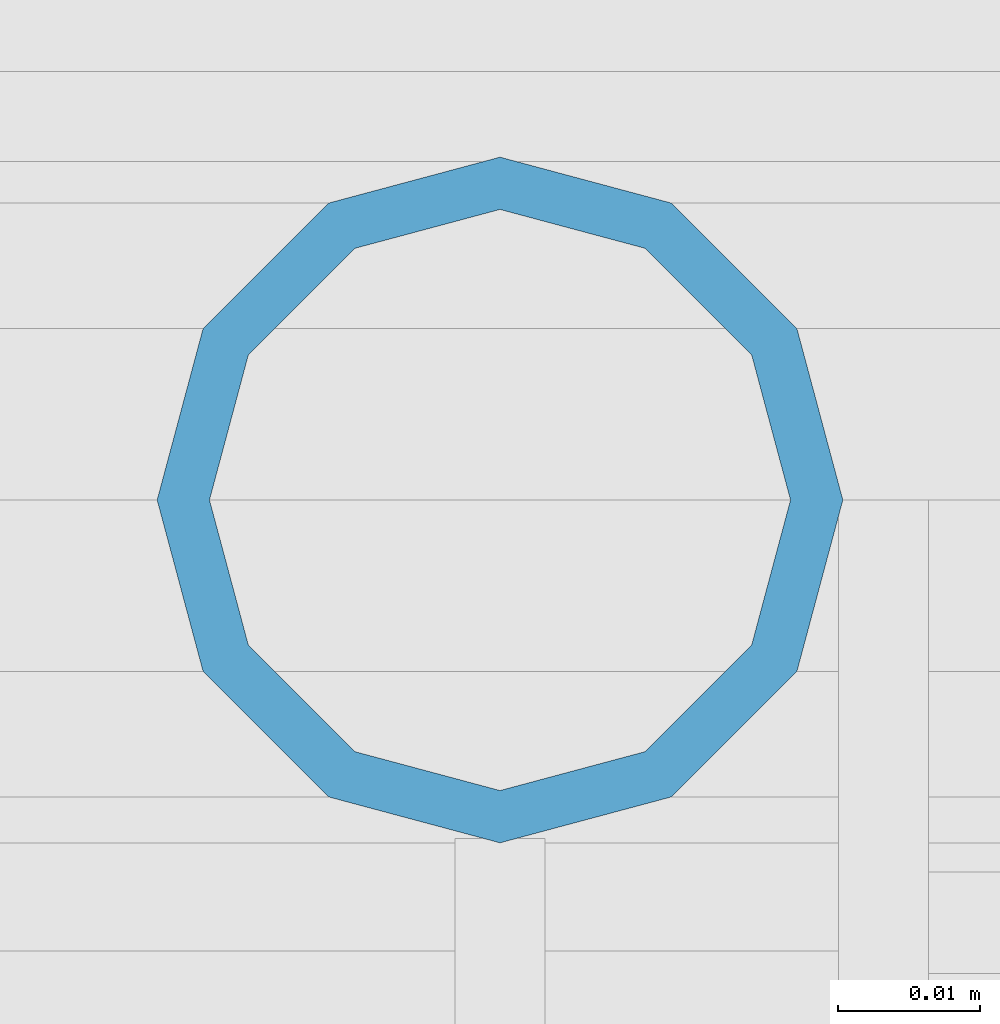
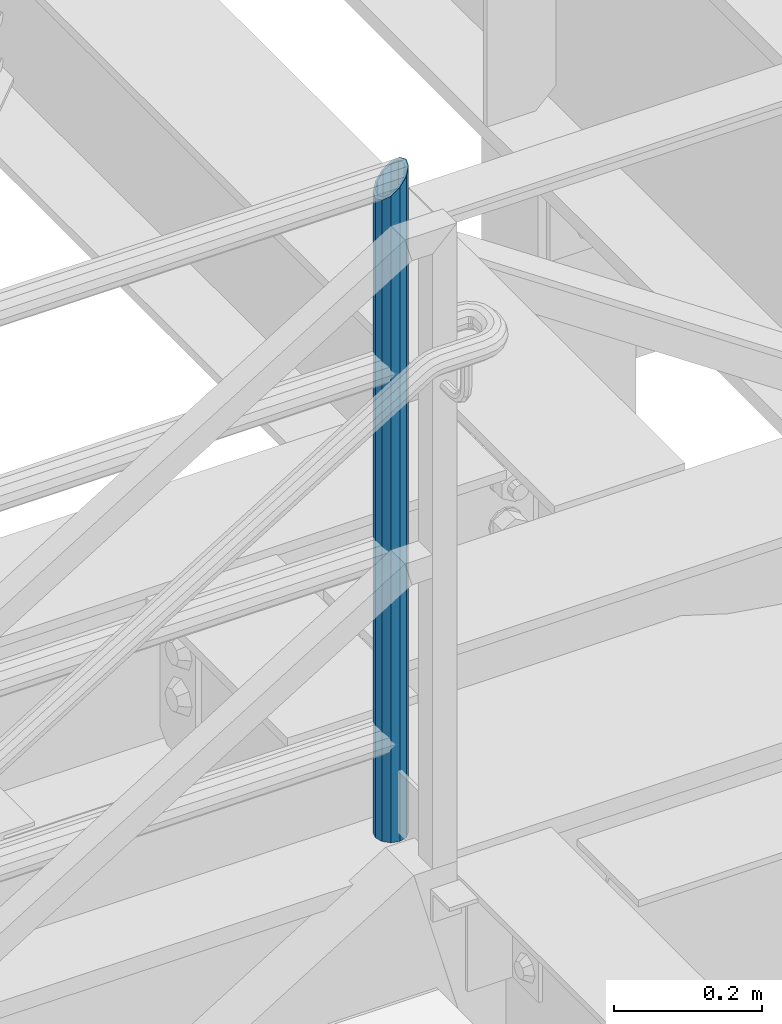
# One storey, part 647 of 1876: 1 column, 1 element without a shape of its own.
"""IFC2X3 building model written with IfcOpenShell, lengths in millimetres."""

import ifcopenshell
import ifcopenshell.guid

model = None  # the IFC model being written
_history = None  # IfcOwnerHistory: only IFC2X3 demands one
_inside = {}  # id of a spatial element -> (the spatial element, [elements in it])
_under = {}  # id of a project, library or spatial element -> (it, [spatial elements below it])
_declared = {}  # id of a project -> (the project, [libraries it declares])
_typed = {}  # id of a type object -> (the type object, [elements of that type])
_made_of = {}  # id of a material, layer set ... -> (it, [elements and type objects made of it])


def new_model(schema):
    """Start an empty IFC model of exactly this schema.

    Asked for "IFC4X3", IfcOpenShell would pick the latest addendum, in which some entities
    have other attributes; the version numbers below select the first issue.
    IFC2X3 requires an IfcOwnerHistory on every rooted entity: one is made here for all.
    """
    global model, _history
    if schema == "IFC4X3":
        model = ifcopenshell.file(schema_version=(4, 3, 0, 0))
    else:
        model = ifcopenshell.file(schema=schema)
    _inside.clear()
    _under.clear()
    _declared.clear()
    _typed.clear()
    _made_of.clear()
    _history = None
    if model.schema == "IFC2X3":
        org = make("IfcOrganization", Name="unknown")
        user = make(
            "IfcPersonAndOrganization",
            ThePerson=make("IfcPerson", FamilyName="unknown"),
            TheOrganization=org,
        )
        app = make(
            "IfcApplication",
            ApplicationDeveloper=org,
            Version="unknown",
            ApplicationFullName="unknown",
            ApplicationIdentifier="unknown",
        )
        _history = make(
            "IfcOwnerHistory",
            OwningUser=user,
            OwningApplication=app,
            ChangeAction="ADDED",
            CreationDate=0,
        )
    return model


def make(cls, **values):
    """One entity of the class cls with the attributes given. An attribute that is None is left unset."""
    return model.create_entity(
        cls, **{name: value for name, value in values.items() if value is not None}
    )


def rooted(cls, **values):
    """An entity with a GlobalId (a new one), such as an element, a storey or a relation."""
    return make(cls, GlobalId=ifcopenshell.guid.new(), OwnerHistory=_history, **values)


def si_unit(unit_type, name, prefix=None):
    """IfcSIUnit, for example si_unit("LENGTHUNIT", "METRE", prefix="MILLI")."""
    return make("IfcSIUnit", UnitType=unit_type, Prefix=prefix, Name=name)


def assignment(units):
    """IfcUnitAssignment: the units of a project."""
    return None if units is None else make("IfcUnitAssignment", Units=units)


def point(xyz):
    """IfcCartesianPoint."""
    return None if xyz is None else make("IfcCartesianPoint", Coordinates=xyz)


def direction(xyz):
    """IfcDirection."""
    return None if xyz is None else make("IfcDirection", DirectionRatios=xyz)


def frame(location, z_axis=None, x_axis=None):
    """IfcAxis2Placement3D, a coordinate frame: its origin and axes. An axis left out is left unset."""
    return make(
        "IfcAxis2Placement3D",
        Location=point(location),
        Axis=direction(z_axis),
        RefDirection=direction(x_axis),
    )


def origin_with_axes():
    """The frame at (0, 0, 0) with the z axis (0, 0, 1) and the x axis (1, 0, 0) written out."""
    return frame((0.0, 0.0, 0.0), z_axis=(0.0, 0.0, 1.0), x_axis=(1.0, 0.0, 0.0))


def place(relative_to, where):
    """IfcLocalPlacement: puts the frame where relative to a parent placement (None: the world)."""
    return make(
        "IfcLocalPlacement", PlacementRelTo=relative_to, RelativePlacement=where
    )


def context(
    kind, dimensions, precision=None, world=None, true_north=None, identifier=None
):
    """IfcGeometricRepresentationContext, for example the 3D "Model" context."""
    return make(
        "IfcGeometricRepresentationContext",
        ContextIdentifier=identifier,
        ContextType=kind,
        CoordinateSpaceDimension=dimensions,
        Precision=precision,
        WorldCoordinateSystem=world,
        TrueNorth=true_north,
    )


def subcontext(parent, identifier, kind, view, scale=None):
    """IfcGeometricRepresentationSubContext, for example "Body" below "Model"."""
    return make(
        "IfcGeometricRepresentationSubContext",
        ContextIdentifier=identifier,
        ContextType=kind,
        ParentContext=parent,
        TargetScale=scale,
        TargetView=view,
    )


def project(units=None, contexts=None):
    """IfcProject with its units and contexts."""
    return rooted(
        "IfcProject",
        Name="project",
        RepresentationContexts=contexts,
        UnitsInContext=assignment(units),
    )


def spatial(cls, under=None, at=None, **own):
    """A site, building, storey or space (cls), placed at a placement, below another one or the project."""
    s = rooted(cls, ObjectPlacement=at, **own)
    if under is not None:
        _under.setdefault(under.id(), (under, []))[1].append(s)
    return s


def faces_of(points, faces, orient=None, outer=None):
    """IfcFace entities. A face is a list of loops; a loop is a list of indices into points, from 0.

    orient and outer hold one flag for each loop. By default every Orientation is true, the
    first loop of a face is its IfcFaceOuterBound and the others are IfcFaceBound.
    """
    made = []
    for i, loops in enumerate(faces):
        bounds = []
        for j, loop in enumerate(loops):
            is_outer = j == 0 if outer is None else outer[i][j]
            bounds.append(
                make(
                    "IfcFaceOuterBound" if is_outer else "IfcFaceBound",
                    Bound=make("IfcPolyLoop", Polygon=[points[k] for k in loop]),
                    Orientation=True if orient is None else orient[i][j],
                )
            )
        made.append(make("IfcFace", Bounds=bounds))
    return made


def faceted_brep(points, faces, orient=None, outer=None, voids=None):
    """IfcFacetedBrep: a solid bounded by flat faces; with voids (closed shells), ...WithVoids."""
    shared = [point(p) for p in points]
    hull = make("IfcClosedShell", CfsFaces=faces_of(shared, faces, orient, outer))
    if voids is None:
        return make("IfcFacetedBrep", Outer=hull)
    return make(
        "IfcFacetedBrepWithVoids",
        Outer=hull,
        Voids=[
            make(cls, CfsFaces=faces_of(shared, fs, o, b)) for cls, fs, o, b in voids
        ],
    )


def shape(context_of_items, identifier, shape_type, items):
    """IfcShapeRepresentation: the items that make up one representation, for example the "Body"."""
    return make(
        "IfcShapeRepresentation",
        ContextOfItems=context_of_items,
        RepresentationIdentifier=identifier,
        RepresentationType=shape_type,
        Items=items,
    )


def material(Name=None, Category=None):
    """IfcMaterial."""
    return make("IfcMaterial", Name=Name, Category=Category)


def made_of(thing, what):
    """Note that an element or type object is made of a material, layer set ...; save() writes the relation."""
    if what is not None:
        _made_of.setdefault(what.id(), (what, []))[1].append(thing)
    return thing


def type_object(cls, material=None, **own):
    """A type object (cls), such as IfcWallType, which elements share."""
    return made_of(rooted(cls, **own), material)


def element(
    cls,
    number,
    at=None,
    inside=None,
    cuts=None,
    type_object=None,
    material=None,
    context=None,
    identifier="Body",
    shape_type=None,
    held_by="IfcProductDefinitionShape",
    body=None,
    shapes=None,
    **own,
):
    """One element of the class cls, such as IfcWall. Its Tag is "e" and its number.

    at: its placement. inside: the storey or other place that contains it. cuts: it is an
    opening in that element (IfcRelVoidsElement). A single representation is given by context,
    identifier, shape_type and body (its items); several are given by shapes. held_by: the class
    of the entity that holds the representations. save() writes the other relations.
    """
    e = rooted(cls, Tag="e%d" % number, ObjectPlacement=at, **own)
    if body is not None:
        shapes = [shape(context, identifier, shape_type, body)]
    if shapes is not None:
        e.Representation = make(held_by, Representations=shapes)
    if inside is not None:
        _inside.setdefault(inside.id(), (inside, []))[1].append(e)
    if cuts is not None:
        rooted(
            "IfcRelVoidsElement", RelatingBuildingElement=cuts, RelatedOpeningElement=e
        )
    if type_object is not None:
        _typed.setdefault(type_object.id(), (type_object, []))[1].append(e)
    return made_of(e, material)


def aggregate(whole, parts):
    """IfcRelAggregates: a whole, such as a stair, and the parts it consists of."""
    return rooted("IfcRelAggregates", RelatingObject=whole, RelatedObjects=parts)


def save(model, path):
    """Write the relations noted so far, then the file.

    IfcRelAggregates (storeys below a building ...), IfcRelContainedInSpatialStructure (elements
    in a storey), IfcRelDefinesByType, IfcRelAssociatesMaterial and IfcRelDeclares: one each for
    every whole, place, type object, material and project.
    """
    for whole, parts in _under.values():
        aggregate(whole, parts)
    for where, things in _inside.values():
        rooted(
            "IfcRelContainedInSpatialStructure",
            RelatedElements=things,
            RelatingStructure=where,
        )
    for kind, things in _typed.values():
        rooted("IfcRelDefinesByType", RelatedObjects=things, RelatingType=kind)
    for what, things in _made_of.values():
        rooted("IfcRelAssociatesMaterial", RelatedObjects=things, RelatingMaterial=what)
    for by, libraries in _declared.values():
        rooted("IfcRelDeclares", RelatingContext=by, RelatedDefinitions=libraries)
    model.write(path)


model = new_model("IFC2X3")

# Units and contexts
model_context = context("Model", 3, precision=1e-05, world=origin_with_axes())
body_context = subcontext(model_context, "Body", "Model", "MODEL_VIEW")
ifc_project = project(units=[si_unit("LENGTHUNIT", "METRE", prefix="MILLI"), si_unit("AREAUNIT", "SQUARE_METRE"), si_unit("VOLUMEUNIT", "CUBIC_METRE"), si_unit("MASSUNIT", "GRAM", prefix="KILO"), si_unit("TIMEUNIT", "SECOND"), si_unit("PLANEANGLEUNIT", "RADIAN"), si_unit("SOLIDANGLEUNIT", "STERADIAN"), si_unit("THERMODYNAMICTEMPERATUREUNIT", "DEGREE_CELSIUS"), si_unit("LUMINOUSINTENSITYUNIT", "LUMEN")], contexts=[model_context])

# Site, building, storey
site_placement = place(None, origin_with_axes())
site = spatial("IfcSite", under=ifc_project, at=site_placement, CompositionType="ELEMENT")
building_placement = place(site_placement, origin_with_axes())
building = spatial("IfcBuilding", under=site, at=building_placement, Name="Undefined", CompositionType="ELEMENT")
storey_placement = place(building_placement, origin_with_axes())
storey = spatial("IfcBuildingStorey", under=building, at=storey_placement, Name="Undefined", CompositionType="ELEMENT", Elevation=0.0)

# Assembly, column
assembly_placement = place(storey_placement, origin_with_axes())
assembly = element("IfcElementAssembly", 1, at=assembly_placement, inside=storey, Name="RAIL", AssemblyPlace="NOTDEFINED", PredefinedType="RIGID_FRAME")
ifc_material = material()
column_type = type_object("IfcColumnType", Name="PIPE1-1/2SCH40", PredefinedType="NOTDEFINED")
column_placement = place(assembly_placement, frame((6137.27499995291, -4654.55000114554, 13309.6), z_axis=(0.0, 1.0, 0.0), x_axis=(0.0, 0.0, 1.0)))
column = element("IfcColumn", 2, at=column_placement, type_object=column_type, material=ifc_material, Name="POST", ObjectType="PIPE1-1/2SCH40", context=body_context, shape_type="Brep", body=[
    faceted_brep([(0.0, -20.4469999999999, 0.0), (0.0, -17.7076214311803, 10.2235000000001), (1058.61737856882, -17.7076214311803, 10.2235000000001), (1055.878, -20.4469999999999, 0.0), (0.0, -10.2235000000001, 17.7076214311801), (1066.1015, -10.2235000000001, 17.7076214311801), (-1.45519152283669e-11, 0.0, 20.4470000000001), (1076.325, 0.0, 20.4470000000001), (0.0, 10.2235000000001, 17.7076214311801), (1086.5485, 10.2235000000001, 17.7076214311801), (0.0, 17.7076214311803, 10.2235000000001), (1094.03262143118, 17.7076214311803, 10.2235000000001), (0.0, 20.4469999999999, 0.0), (1096.772, 20.4469999999999, 0.0), (0.0, 17.7076214311803, -10.2235000000001), (1094.03262143118, 17.7076214311803, -10.2235000000001), (0.0, 10.2235000000001, -17.7076214311801), (1086.5485, 10.2235000000001, -17.7076214311801), (-1.45519152283669e-11, 0.0, -20.4470000000001), (1076.325, 0.0, -20.4470000000001), (0.0, -10.2235000000001, -17.7076214311801), (1066.1015, -10.2235000000001, -17.7076214311801), (0.0, -17.7076214311803, -10.2235000000001), (1058.61737856882, -17.7076214311803, -10.2235000000001), (0.0, -24.1299999999992, 0.0), (0.0, -20.8971929933184, -12.0649999999996), (1055.42780700668, -20.8971929933184, -12.0649999999996), (1052.195, -24.1300000000001, 0.0), (0.0, -12.0650000000001, -20.8971929933186), (1064.26, -12.0650000000001, -20.8971929933186), (-1.45519152283669e-11, 0.0, -24.130000000001), (1076.325, 0.0, -24.1300000000001), (0.0, 12.0650000000001, -20.8971929933186), (1088.39, 12.0650000000001, -20.8971929933186), (0.0, 20.8971929933184, -12.0649999999996), (1097.22219299332, 20.8971929933184, -12.0649999999996), (0.0, 24.1299999999992, 0.0), (1100.455, 24.1300000000001, 0.0), (0.0, 20.8971929933184, 12.0649999999996), (1097.22219299332, 20.8971929933184, 12.0649999999996), (0.0, 12.0650000000001, 20.8971929933186), (1088.39, 12.0650000000001, 20.8971929933186), (-1.45519152283669e-11, 0.0, 24.130000000001), (1076.325, 0.0, 24.1300000000001), (0.0, -12.0650000000001, 20.8971929933186), (1064.26, -12.0650000000001, 20.8971929933186), (0.0, -20.8971929933184, 12.0649999999996), (1055.42780700668, -20.8971929933184, 12.0649999999996)], [[[0, 1, 2, 3]], [[1, 4, 5, 2]], [[4, 6, 7, 5]], [[6, 8, 9, 7]], [[8, 10, 11, 9]], [[10, 12, 13, 11]], [[12, 14, 15, 13]], [[14, 16, 17, 15]], [[16, 18, 19, 17]], [[18, 20, 21, 19]], [[20, 22, 23, 21]], [[22, 0, 3, 23]], [[24, 25, 26, 27]], [[25, 28, 29, 26]], [[28, 30, 31, 29]], [[30, 32, 33, 31]], [[32, 34, 35, 33]], [[34, 36, 37, 35]], [[36, 38, 39, 37]], [[38, 40, 41, 39]], [[40, 42, 43, 41]], [[42, 44, 45, 43]], [[44, 46, 47, 45]], [[46, 24, 27, 47]], [[29, 31, 33, 35, 37, 39, 41, 43, 45, 47, 27, 26], [5, 7, 9, 11, 13, 15, 17, 19, 21, 23, 3, 2]], [[46, 44, 42, 40, 38, 36, 34, 32, 30, 28, 25, 24], [22, 20, 18, 16, 14, 12, 10, 8, 6, 4, 1, 0]]]),
])
aggregate(assembly, [column])

save(model, "model.ifc")
